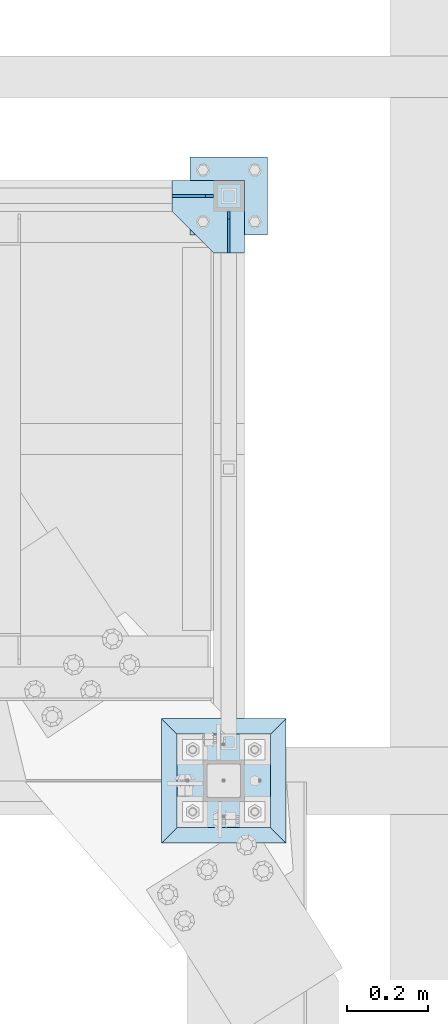
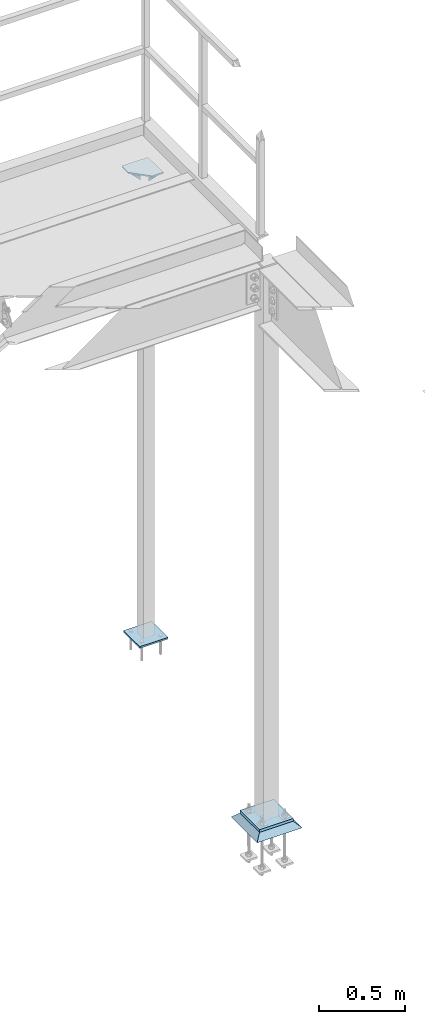
# One storey, part 3417 of 3843: 6 plates, 3 elements without a shape of their own.
"""IFC2X3 building model written with IfcOpenShell, lengths in millimetres."""

import ifcopenshell
import ifcopenshell.guid

model = None  # the IFC model being written
_history = None  # IfcOwnerHistory: only IFC2X3 demands one
_inside = {}  # id of a spatial element -> (the spatial element, [elements in it])
_under = {}  # id of a project, library or spatial element -> (it, [spatial elements below it])
_declared = {}  # id of a project -> (the project, [libraries it declares])
_typed = {}  # id of a type object -> (the type object, [elements of that type])
_made_of = {}  # id of a material, layer set ... -> (it, [elements and type objects made of it])


def new_model(schema):
    """Start an empty IFC model of exactly this schema.

    Asked for "IFC4X3", IfcOpenShell would pick the latest addendum, in which some entities
    have other attributes; the version numbers below select the first issue.
    IFC2X3 requires an IfcOwnerHistory on every rooted entity: one is made here for all.
    """
    global model, _history
    if schema == "IFC4X3":
        model = ifcopenshell.file(schema_version=(4, 3, 0, 0))
    else:
        model = ifcopenshell.file(schema=schema)
    _inside.clear()
    _under.clear()
    _declared.clear()
    _typed.clear()
    _made_of.clear()
    _history = None
    if model.schema == "IFC2X3":
        org = make("IfcOrganization", Name="unknown")
        user = make(
            "IfcPersonAndOrganization",
            ThePerson=make("IfcPerson", FamilyName="unknown"),
            TheOrganization=org,
        )
        app = make(
            "IfcApplication",
            ApplicationDeveloper=org,
            Version="unknown",
            ApplicationFullName="unknown",
            ApplicationIdentifier="unknown",
        )
        _history = make(
            "IfcOwnerHistory",
            OwningUser=user,
            OwningApplication=app,
            ChangeAction="ADDED",
            CreationDate=0,
        )
    return model


def make(cls, **values):
    """One entity of the class cls with the attributes given. An attribute that is None is left unset."""
    return model.create_entity(
        cls, **{name: value for name, value in values.items() if value is not None}
    )


def rooted(cls, **values):
    """An entity with a GlobalId (a new one), such as an element, a storey or a relation."""
    return make(cls, GlobalId=ifcopenshell.guid.new(), OwnerHistory=_history, **values)


def si_unit(unit_type, name, prefix=None):
    """IfcSIUnit, for example si_unit("LENGTHUNIT", "METRE", prefix="MILLI")."""
    return make("IfcSIUnit", UnitType=unit_type, Prefix=prefix, Name=name)


def assignment(units):
    """IfcUnitAssignment: the units of a project."""
    return None if units is None else make("IfcUnitAssignment", Units=units)


def point(xyz):
    """IfcCartesianPoint."""
    return None if xyz is None else make("IfcCartesianPoint", Coordinates=xyz)


def direction(xyz):
    """IfcDirection."""
    return None if xyz is None else make("IfcDirection", DirectionRatios=xyz)


def frame(location, z_axis=None, x_axis=None):
    """IfcAxis2Placement3D, a coordinate frame: its origin and axes. An axis left out is left unset."""
    return make(
        "IfcAxis2Placement3D",
        Location=point(location),
        Axis=direction(z_axis),
        RefDirection=direction(x_axis),
    )


def origin_with_axes():
    """The frame at (0, 0, 0) with the z axis (0, 0, 1) and the x axis (1, 0, 0) written out."""
    return frame((0.0, 0.0, 0.0), z_axis=(0.0, 0.0, 1.0), x_axis=(1.0, 0.0, 0.0))


def place(relative_to, where):
    """IfcLocalPlacement: puts the frame where relative to a parent placement (None: the world)."""
    return make(
        "IfcLocalPlacement", PlacementRelTo=relative_to, RelativePlacement=where
    )


def context(
    kind, dimensions, precision=None, world=None, true_north=None, identifier=None
):
    """IfcGeometricRepresentationContext, for example the 3D "Model" context."""
    return make(
        "IfcGeometricRepresentationContext",
        ContextIdentifier=identifier,
        ContextType=kind,
        CoordinateSpaceDimension=dimensions,
        Precision=precision,
        WorldCoordinateSystem=world,
        TrueNorth=true_north,
    )


def subcontext(parent, identifier, kind, view, scale=None):
    """IfcGeometricRepresentationSubContext, for example "Body" below "Model"."""
    return make(
        "IfcGeometricRepresentationSubContext",
        ContextIdentifier=identifier,
        ContextType=kind,
        ParentContext=parent,
        TargetScale=scale,
        TargetView=view,
    )


def project(units=None, contexts=None):
    """IfcProject with its units and contexts."""
    return rooted(
        "IfcProject",
        Name="project",
        RepresentationContexts=contexts,
        UnitsInContext=assignment(units),
    )


def spatial(cls, under=None, at=None, **own):
    """A site, building, storey or space (cls), placed at a placement, below another one or the project."""
    s = rooted(cls, ObjectPlacement=at, **own)
    if under is not None:
        _under.setdefault(under.id(), (under, []))[1].append(s)
    return s


def faces_of(points, faces, orient=None, outer=None):
    """IfcFace entities. A face is a list of loops; a loop is a list of indices into points, from 0.

    orient and outer hold one flag for each loop. By default every Orientation is true, the
    first loop of a face is its IfcFaceOuterBound and the others are IfcFaceBound.
    """
    made = []
    for i, loops in enumerate(faces):
        bounds = []
        for j, loop in enumerate(loops):
            is_outer = j == 0 if outer is None else outer[i][j]
            bounds.append(
                make(
                    "IfcFaceOuterBound" if is_outer else "IfcFaceBound",
                    Bound=make("IfcPolyLoop", Polygon=[points[k] for k in loop]),
                    Orientation=True if orient is None else orient[i][j],
                )
            )
        made.append(make("IfcFace", Bounds=bounds))
    return made


def faceted_brep(points, faces, orient=None, outer=None, voids=None):
    """IfcFacetedBrep: a solid bounded by flat faces; with voids (closed shells), ...WithVoids."""
    shared = [point(p) for p in points]
    hull = make("IfcClosedShell", CfsFaces=faces_of(shared, faces, orient, outer))
    if voids is None:
        return make("IfcFacetedBrep", Outer=hull)
    return make(
        "IfcFacetedBrepWithVoids",
        Outer=hull,
        Voids=[
            make(cls, CfsFaces=faces_of(shared, fs, o, b)) for cls, fs, o, b in voids
        ],
    )


def shape(context_of_items, identifier, shape_type, items):
    """IfcShapeRepresentation: the items that make up one representation, for example the "Body"."""
    return make(
        "IfcShapeRepresentation",
        ContextOfItems=context_of_items,
        RepresentationIdentifier=identifier,
        RepresentationType=shape_type,
        Items=items,
    )


def material(Name=None, Category=None):
    """IfcMaterial."""
    return make("IfcMaterial", Name=Name, Category=Category)


def made_of(thing, what):
    """Note that an element or type object is made of a material, layer set ...; save() writes the relation."""
    if what is not None:
        _made_of.setdefault(what.id(), (what, []))[1].append(thing)
    return thing


def type_object(cls, material=None, **own):
    """A type object (cls), such as IfcWallType, which elements share."""
    return made_of(rooted(cls, **own), material)


def element(
    cls,
    number,
    at=None,
    inside=None,
    cuts=None,
    type_object=None,
    material=None,
    context=None,
    identifier="Body",
    shape_type=None,
    held_by="IfcProductDefinitionShape",
    body=None,
    shapes=None,
    **own,
):
    """One element of the class cls, such as IfcWall. Its Tag is "e" and its number.

    at: its placement. inside: the storey or other place that contains it. cuts: it is an
    opening in that element (IfcRelVoidsElement). A single representation is given by context,
    identifier, shape_type and body (its items); several are given by shapes. held_by: the class
    of the entity that holds the representations. save() writes the other relations.
    """
    e = rooted(cls, Tag="e%d" % number, ObjectPlacement=at, **own)
    if body is not None:
        shapes = [shape(context, identifier, shape_type, body)]
    if shapes is not None:
        e.Representation = make(held_by, Representations=shapes)
    if inside is not None:
        _inside.setdefault(inside.id(), (inside, []))[1].append(e)
    if cuts is not None:
        rooted(
            "IfcRelVoidsElement", RelatingBuildingElement=cuts, RelatedOpeningElement=e
        )
    if type_object is not None:
        _typed.setdefault(type_object.id(), (type_object, []))[1].append(e)
    return made_of(e, material)


def aggregate(whole, parts):
    """IfcRelAggregates: a whole, such as a stair, and the parts it consists of."""
    return rooted("IfcRelAggregates", RelatingObject=whole, RelatedObjects=parts)


def save(model, path):
    """Write the relations noted so far, then the file.

    IfcRelAggregates (storeys below a building ...), IfcRelContainedInSpatialStructure (elements
    in a storey), IfcRelDefinesByType, IfcRelAssociatesMaterial and IfcRelDeclares: one each for
    every whole, place, type object, material and project.
    """
    for whole, parts in _under.values():
        aggregate(whole, parts)
    for where, things in _inside.values():
        rooted(
            "IfcRelContainedInSpatialStructure",
            RelatedElements=things,
            RelatingStructure=where,
        )
    for kind, things in _typed.values():
        rooted("IfcRelDefinesByType", RelatedObjects=things, RelatingType=kind)
    for what, things in _made_of.values():
        rooted("IfcRelAssociatesMaterial", RelatedObjects=things, RelatingMaterial=what)
    for by, libraries in _declared.values():
        rooted("IfcRelDeclares", RelatingContext=by, RelatedDefinitions=libraries)
    model.write(path)


model = new_model("IFC2X3")

# Units and contexts
model_context = context("Model", 3, precision=1e-05, world=origin_with_axes())
body_context = subcontext(model_context, "Body", "Model", "MODEL_VIEW")
ifc_project = project(units=[si_unit("LENGTHUNIT", "METRE", prefix="MILLI"), si_unit("AREAUNIT", "SQUARE_METRE"), si_unit("VOLUMEUNIT", "CUBIC_METRE"), si_unit("MASSUNIT", "GRAM", prefix="KILO"), si_unit("TIMEUNIT", "SECOND"), si_unit("PLANEANGLEUNIT", "RADIAN"), si_unit("SOLIDANGLEUNIT", "STERADIAN"), si_unit("THERMODYNAMICTEMPERATUREUNIT", "DEGREE_CELSIUS"), si_unit("LUMINOUSINTENSITYUNIT", "LUMEN")], contexts=[model_context])

# Site, building, storey
site_placement = place(None, origin_with_axes())
site = spatial("IfcSite", under=ifc_project, at=site_placement, CompositionType="ELEMENT")
building_placement = place(site_placement, origin_with_axes())
building = spatial("IfcBuilding", under=site, at=building_placement, Name="Undefined", CompositionType="ELEMENT")
storey_placement = place(building_placement, origin_with_axes())
storey = spatial("IfcBuildingStorey", under=building, at=storey_placement, Name="Undefined", CompositionType="ELEMENT", Elevation=0.0)

# Assembly, plates
assembly_1_placement = place(storey_placement, origin_with_axes())
assembly_1 = element("IfcElementAssembly", 1, at=assembly_1_placement, inside=storey, Name="POST", AssemblyPlace="NOTDEFINED", PredefinedType="RIGID_FRAME")
ifc_material_1 = material(Name="STEEL/A36")
plate_type_1 = type_object("IfcPlateType", PredefinedType="NOTDEFINED")
plate_1_placement = place(assembly_1_placement, frame((38833.4249999936, 90512.9000000994, 33848.6749999998), z_axis=(0.0, 0.0, -1.0), x_axis=(0.0, -1.0, 0.0)))
plate_1 = element("IfcPlate", 2, at=plate_1_placement, type_object=plate_type_1, material=ifc_material_1, Name="PLATE", context=body_context, shape_type="Brep", body=[
    faceted_brep([(4.36557456851006e-11, -3.17499999998836, 19.0499992370969), (0.0, -3.17499999999927, 101.600000000006), (0.0, 3.17499999999927, 101.600000000006), (1.45519152283669e-11, 3.17499999998836, 19.0499992370824), (101.600000000035, -3.17500000000291, -7.27595761418343e-12), (101.600000000035, 3.17500000000291, -7.27595761418343e-12), (19.0499992370023, -3.17500000005384, 0.0), (19.0499992369587, 3.17499999992287, -1.45519152283669e-11)], [[[0, 1, 2, 3]], [[1, 4, 5, 2]], [[4, 6, 7, 5]], [[6, 0, 3, 7]], [[5, 7, 3, 2]], [[6, 4, 1, 0]]]),
])
plate_2_placement = place(assembly_1_placement, frame((38795.3249999937, 90551.0000000994, 33848.6749999998), z_axis=(0.0, 0.0, -1.0), x_axis=(-1.0, 0.0, 0.0)))
plate_2 = element("IfcPlate", 3, at=plate_2_placement, type_object=plate_type_1, material=ifc_material_1, Name="PLATE", context=body_context, shape_type="Brep", body=[
    faceted_brep([(4.36557456851006e-11, -3.17499999998836, 19.0499992370969), (0.0, -3.17499999999927, 101.600000000006), (0.0, 3.17499999999927, 101.600000000006), (1.45519152283669e-11, 3.17499999998836, 19.0499992370824), (101.600000000035, -3.17500000000291, -7.27595761418343e-12), (101.600000000035, 3.17500000000291, -7.27595761418343e-12), (19.0499992370023, -3.17500000005384, 0.0), (19.0499992369587, 3.17499999992287, -1.45519152283669e-11)], [[[0, 1, 2, 3]], [[1, 4, 5, 2]], [[4, 6, 7, 5]], [[6, 0, 3, 7]], [[5, 7, 3, 2]], [[6, 4, 1, 0]]]),
])
plate_type_2 = type_object("IfcPlateType", PredefinedType="NOTDEFINED")
plate_3_placement = place(assembly_1_placement, frame((38738.1749999937, 90455.7500000994, 30486.3499999999), z_axis=(0.0, 1.0, 0.0), x_axis=(1.0, 0.0, 0.0)))
plate_3 = element("IfcPlate", 4, at=plate_3_placement, type_object=plate_type_2, material=ifc_material_1, Name="PLATE", context=body_context, shape_type="Brep", body=[
    faceted_brep([(0.0, -6.3499999046162, 0.0), (0.0, -6.34999999999854, 190.5), (0.0, 6.34999999999854, 190.5), (7.27595761418343e-12, 6.3499999046162, 0.0), (190.5, -6.34999999999854, 190.5), (190.5, 6.34999999999854, 190.5), (190.5, -6.34999999999854, 0.0), (190.5, 6.34999999999854, 0.0)], [[[0, 1, 2, 3]], [[1, 4, 5, 2]], [[4, 6, 7, 5]], [[6, 0, 3, 7]], [[5, 7, 3, 2]], [[6, 4, 1, 0]]]),
])
plate_type_3 = type_object("IfcPlateType", PredefinedType="NOTDEFINED")
plate_4_placement = place(assembly_1_placement, frame((38871.5249999936, 90589.1000000963, 33853.4374999998), z_axis=(-1.0, 0.0, 0.0), x_axis=(0.0, -1.0, 0.0)))
plate_4 = element("IfcPlate", 5, at=plate_4_placement, type_object=plate_type_3, material=ifc_material_1, Name="PLATE", context=body_context, shape_type="Brep", body=[
    faceted_brep([(0.0, -4.76249999999709, 0.0), (0.0, -4.76249999999709, 177.800000000003), (0.0, 4.76249999999709, 177.800000000003), (0.0, 4.76249999999709, 0.0), (76.1999999460968, -4.76249999999709, 177.799999999988), (76.1999999460968, 4.76249999999709, 177.799999999988), (177.800000000003, -4.76249999999709, 76.1999999999971), (177.800000000003, 4.76249999999709, 76.1999999999971), (177.800000000003, -4.76249999999709, -1.45519152283669e-11), (177.800000000003, 4.76249999999709, -1.45519152283669e-11)], [[[0, 1, 2, 3]], [[1, 4, 5, 2]], [[4, 6, 7, 5]], [[6, 8, 9, 7]], [[8, 0, 3, 9]], [[5, 7, 9, 3, 2]], [[8, 6, 4, 1, 0]]]),
])
aggregate(assembly_1, [plate_1, plate_2, plate_3, plate_4])

# Assembly, plate
assembly_2_placement = place(storey_placement, origin_with_axes())
assembly_2 = element("IfcElementAssembly", 6, at=assembly_2_placement, inside=storey, Name="COLUMN", AssemblyPlace="NOTDEFINED", PredefinedType="RIGID_FRAME")
ifc_material_2 = material(Name="STEEL/A572-50")
plate_type_4 = type_object("IfcPlateType", PredefinedType="NOTDEFINED")
plate_5_placement = place(assembly_2_placement, frame((38706.425, 89001.6, 30070.425), z_axis=(0.0, 1.0, 0.0), x_axis=(1.0, 0.0, 0.0)))
plate_5 = element("IfcPlate", 7, at=plate_5_placement, type_object=plate_type_4, material=ifc_material_2, Name="PLATE", context=body_context, shape_type="Brep", body=[
    faceted_brep([(0.0, -9.52500000000146, 0.0), (0.0, -9.52500000000146, 228.600006103516), (0.0, 9.52500000000146, 228.600006103516), (0.0, 9.52500000000146, 0.0), (228.600006103516, -9.52500000000146, 228.600006103516), (228.600006103516, 9.52500000000146, 228.600006103516), (228.599999999999, -9.52500000000146, 0.0), (228.599999999999, 9.52500000000146, 0.0)], [[[0, 1, 2, 3]], [[1, 4, 5, 2]], [[4, 6, 7, 5]], [[6, 0, 3, 7]], [[5, 7, 3, 2]], [[6, 4, 1, 0]]]),
])
aggregate(assembly_2, [plate_5])

assembly_3_placement = place(storey_placement, origin_with_axes())
assembly_3 = element("IfcElementAssembly", 8, at=assembly_3_placement, inside=storey, Name="GROUT", AssemblyPlace="NOTDEFINED", PredefinedType="REINFORCEMENT_UNIT")
ifc_material_3 = material(Name="CONCRETE/Concrete_Undefined")
plate_type_5 = type_object("IfcPlateType", PredefinedType="NOTDEFINED")
plate_6_placement = place(assembly_3_placement, frame((38668.325, 88963.5, 30041.85), z_axis=(0.0, 1.0, 0.0), x_axis=(1.0, 0.0, 0.0)))
plate_6 = element("IfcPlate", 9, at=plate_6_placement, type_object=plate_type_5, material=ifc_material_3, Name="GROUT", context=body_context, shape_type="Brep", body=[
    faceted_brep([(38.0999999997875, -19.0499999997883, 266.699999999328), (0.0, 19.0499999999993, 304.799987792969), (0.0, 19.0500000000029, 0.0), (38.1000000006916, -19.0499999999811, 38.1000000006607), (266.700000000201, -19.0499999998174, 38.1000000006752), (304.799987792969, 19.0499999999993, 0.0), (304.799987792969, 19.0499999999993, 304.799987792969), (266.700000000201, -19.0499999999738, 266.699999999328)], [[[0, 1, 2, 3]], [[4, 5, 6, 7]], [[4, 7, 0, 3]], [[5, 4, 3, 2]], [[6, 5, 2, 1]], [[7, 6, 1, 0]]]),
])
aggregate(assembly_3, [plate_6])

save(model, "model.ifc")
